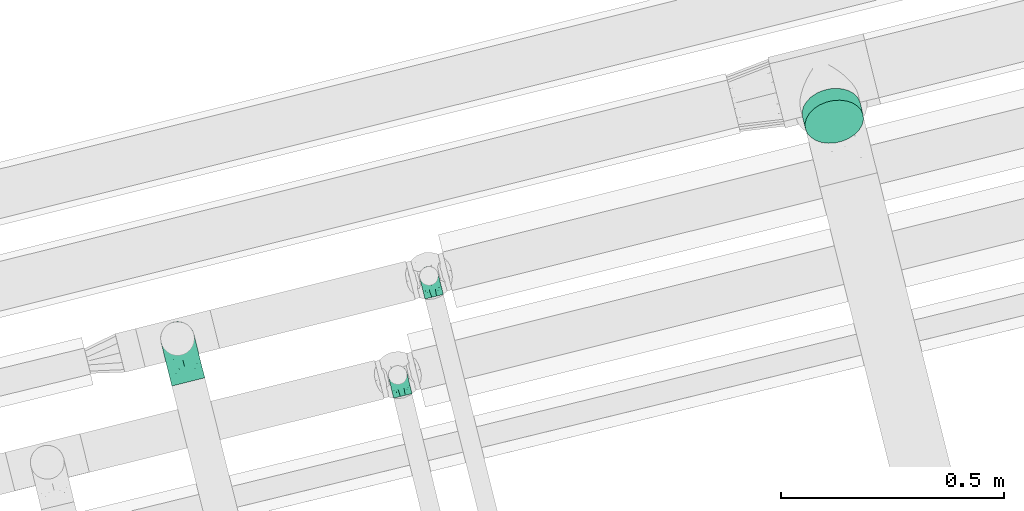
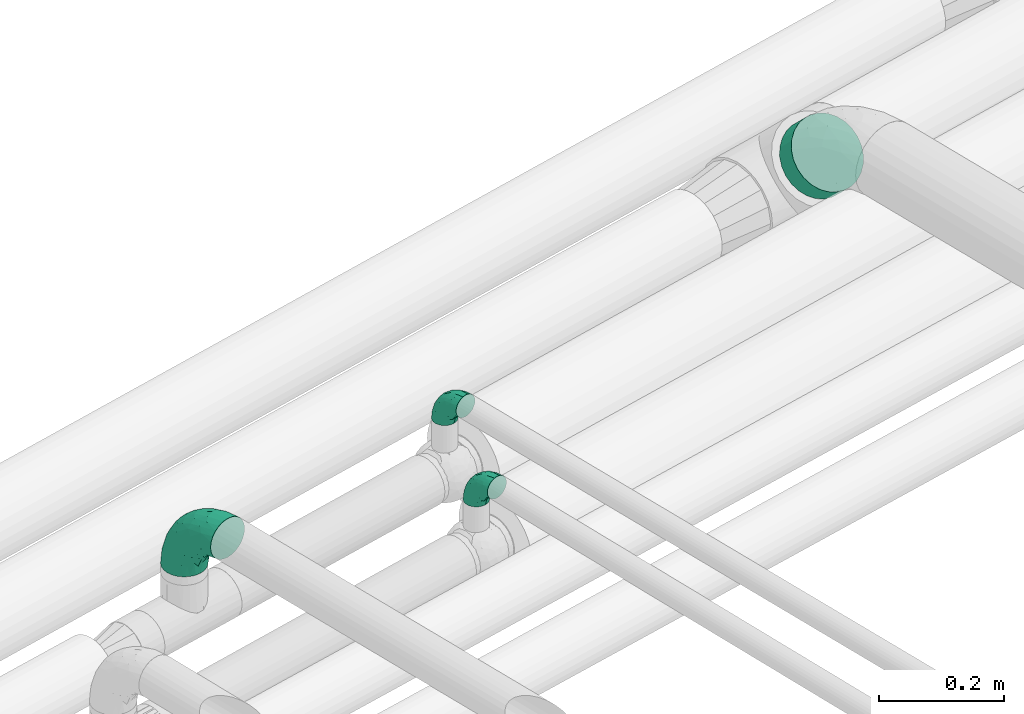
# One storey, part 54 of 93: 3 flow fittings, 1 flow segment.
"""IFC2X3 building model written with IfcOpenShell, lengths in millimetres."""

from ifc_helpers import new_model, entity, si_unit, converted_unit, derived_unit, direction, frame, origin, origin_2d_with_axis, place, context, subcontext, project, spatial, circle, extrude, faceted_brep, source, transform, mapped, material, type_object, type_shapes, element, save


model = new_model("IFC2X3")

# Units and contexts
model_context = context("Model", 3, precision=0.01, world=origin(), true_north=direction((6.12303176911189e-17, 1.0)))
body_context = subcontext(model_context, "Body", "Model", "MODEL_VIEW")
ifc_project = project(units=[si_unit("LENGTHUNIT", "METRE", prefix="MILLI"), si_unit("AREAUNIT", "SQUARE_METRE"), si_unit("VOLUMEUNIT", "CUBIC_METRE"), converted_unit("PLANEANGLEUNIT", "DEGREE", entity("IfcRatioMeasure", 0.0174532925199433), si_unit("PLANEANGLEUNIT", "RADIAN"), dimensions=[0, 0, 0, 0, 0, 0, 0]), si_unit("MASSUNIT", "GRAM", prefix="KILO"), derived_unit("MASSDENSITYUNIT", [(si_unit("MASSUNIT", "GRAM", prefix="KILO"), 1), (si_unit("LENGTHUNIT", "METRE"), -3)]), derived_unit("MOMENTOFINERTIAUNIT", [(si_unit("LENGTHUNIT", "METRE"), 4)]), si_unit("TIMEUNIT", "SECOND"), si_unit("FREQUENCYUNIT", "HERTZ"), si_unit("THERMODYNAMICTEMPERATUREUNIT", "DEGREE_CELSIUS"), derived_unit("THERMALTRANSMITTANCEUNIT", [(si_unit("MASSUNIT", "GRAM", prefix="KILO"), 1), (si_unit("THERMODYNAMICTEMPERATUREUNIT", "KELVIN"), -1), (si_unit("TIMEUNIT", "SECOND"), -3)]), derived_unit("VOLUMETRICFLOWRATEUNIT", [(si_unit("LENGTHUNIT", "METRE"), 3), (si_unit("TIMEUNIT", "SECOND"), -1)]), derived_unit("MASSFLOWRATEUNIT", [(si_unit("MASSUNIT", "GRAM", prefix="KILO"), 1), (si_unit("TIMEUNIT", "SECOND"), -1)]), derived_unit("ROTATIONALFREQUENCYUNIT", [(si_unit("TIMEUNIT", "SECOND"), -1)]), si_unit("ELECTRICCURRENTUNIT", "AMPERE"), si_unit("ELECTRICVOLTAGEUNIT", "VOLT"), si_unit("POWERUNIT", "WATT"), si_unit("FORCEUNIT", "NEWTON", prefix="KILO"), si_unit("ILLUMINANCEUNIT", "LUX"), si_unit("LUMINOUSFLUXUNIT", "LUMEN"), si_unit("LUMINOUSINTENSITYUNIT", "CANDELA"), derived_unit("USERDEFINED", [(si_unit("MASSUNIT", "GRAM", prefix="KILO"), -1), (si_unit("LENGTHUNIT", "METRE"), -2), (si_unit("TIMEUNIT", "SECOND"), 3), (si_unit("LUMINOUSFLUXUNIT", "LUMEN"), 1)]), derived_unit("LINEARVELOCITYUNIT", [(si_unit("LENGTHUNIT", "METRE"), 1), (si_unit("TIMEUNIT", "SECOND"), -1)]), si_unit("PRESSUREUNIT", "PASCAL"), derived_unit("USERDEFINED", [(si_unit("LENGTHUNIT", "METRE"), -2), (si_unit("MASSUNIT", "GRAM", prefix="KILO"), 1), (si_unit("TIMEUNIT", "SECOND"), -2)]), derived_unit("LINEARFORCEUNIT", [(si_unit("MASSUNIT", "GRAM", prefix="KILO"), 1), (si_unit("LENGTHUNIT", "METRE"), 1), (si_unit("TIMEUNIT", "SECOND"), -2), (si_unit("LENGTHUNIT", "METRE"), -1)]), derived_unit("PLANARFORCEUNIT", [(si_unit("MASSUNIT", "GRAM", prefix="KILO"), 1), (si_unit("LENGTHUNIT", "METRE"), 1), (si_unit("TIMEUNIT", "SECOND"), -2), (si_unit("LENGTHUNIT", "METRE"), -2)])], contexts=[model_context])

# Site, building, storey
site_placement = place(None, origin())
site = spatial("IfcSite", under=ifc_project, at=site_placement, CompositionType="ELEMENT")
building_placement = place(site_placement, origin())
building = spatial("IfcBuilding", under=site, at=building_placement, CompositionType="ELEMENT")
storey_placement = place(building_placement, frame((0.0, 0.0, -4200.0)))
storey = spatial("IfcBuildingStorey", under=building, at=storey_placement, CompositionType="ELEMENT", Elevation=-4200.0)

# Flow segment
pipe_segment_type = type_object("IfcPipeSegmentType", PredefinedType="NOTDEFINED")
flow_segment_placement = place(storey_placement, frame((-9939.48, 13051.15, 2518.47)))
element("IfcFlowSegment", 1, at=flow_segment_placement, inside=storey, type_object=pipe_segment_type, context=body_context, shape_type="SweptSolid", body=[
    extrude(circle(Radius=66.5, at=origin_2d_with_axis()), frame((66.89, 76.29, 48.62), z_axis=(0.165599019731802, -0.687453787939549, 0.707095647074307), x_axis=(-0.972191162515673, -0.234188692140385, 0.0)), (0.0, 0.0, 1.0), 38.5556902589995),
])

# Flow fittings
ifc_material = material()
pipe_fitting_type_1 = type_object("IfcPipeFittingType", Name="ADSK_1", PredefinedType="NOTDEFINED", material=ifc_material)
shared_shape_1 = source(origin(), body_context, "Body", "Brep", [
    faceted_brep([(-48.0, 10.6, -18.36), (-48.0, 5.49, -20.48), (-48.0, 0.0, -21.2), (-48.0, -5.49, -20.48), (-48.0, -10.6, -18.36), (-48.0, -14.99, -14.99), (-48.0, -18.36, -10.6), (-48.0, -20.48, -5.49), (-48.0, -21.2, 0.0), (-48.0, -20.48, 5.49), (-48.0, -18.36, 10.6), (-48.0, -14.99, 14.99), (-48.0, -10.6, 18.36), (-48.0, -5.49, 20.48), (-48.0, 0.0, 21.2), (-48.0, 5.49, 20.48), (-48.0, 10.6, 18.36), (-48.0, 14.99, 14.99), (-48.0, 18.36, 10.6), (-48.0, 20.48, 5.49), (-48.0, 21.2, 0.0), (-48.0, 20.48, -5.49), (-48.0, 18.36, -10.6), (-48.0, 14.99, -14.99), (0.0, 48.0, -21.2), (-5.49, 48.0, -20.48), (-10.6, 48.0, -18.36), (-14.99, 48.0, -14.99), (-18.36, 48.0, -10.6), (-20.48, 48.0, -5.49), (-21.2, 48.0, 0.0), (-20.48, 48.0, 5.49), (-18.36, 48.0, 10.6), (-14.99, 48.0, 14.99), (-10.6, 48.0, 18.36), (-5.49, 48.0, 20.48), (0.0, 48.0, 21.2), (5.49, 48.0, 20.48), (10.6, 48.0, 18.36), (14.99, 48.0, 14.99), (18.36, 48.0, 10.6), (20.48, 48.0, 5.49), (21.2, 48.0, 0.0), (20.48, 48.0, -5.49), (18.36, 48.0, -10.6), (14.99, 48.0, -14.99), (10.6, 48.0, -18.36), (5.49, 48.0, -20.48), (-35.25, -16.22, 12.01), (-34.76, -18.57, 0.0), (-20.87, -12.37, 10.9), (-31.49, -11.78, 15.9), (-37.0, -2.58, 20.86), (-33.89, 3.62, 21.15), (-31.81, -18.14, 6.76), (-5.78, 5.78, 17.67), (-19.42, -4.1, 17.86), (-9.6, -3.39, 13.73), (-35.44, -7.73, 19.13), (11.78, 31.49, 15.9), (-5.93, -5.46, 6.95), (-18.45, -13.78, 5.46), (-10.29, -8.43, 0.0), (-24.6, 0.55, 20.62), (-37.28, 17.94, 13.81), (-33.38, 22.85, 9.59), (-41.46, 20.06, 8.75), (-29.51, 20.45, 15.16), (-15.04, 10.79, 21.13), (-7.08, 16.98, 20.93), (-8.39, 23.51, 21.15), (-40.86, 13.03, 17.26), (-8.05, 41.26, 19.83), (-3.21, 35.97, 21.14), (8.53, 19.66, 14.74), (4.1, 19.42, 17.86), (-37.72, 22.66, 4.78), (-37.07, 8.58, 19.98), (-13.0, 5.43, 19.97), (-3.78, 13.93, 19.7), (3.02, 8.69, 13.43), (-2.27, -0.05, 10.65), (6.22, 6.99, 7.09), (-22.25, 34.6, 9.45), (18.14, 31.81, 6.76), (16.22, 35.25, 12.01), (12.37, 20.87, 10.9), (7.73, 35.44, 19.13), (-21.52, -15.93, 0.0), (2.58, 37.0, 20.86), (18.57, 34.76, 0.0), (13.78, 18.45, 5.46), (15.93, 21.52, 0.0), (-20.03, -8.54, 14.9), (-28.6, 28.6, 5.16), (-24.79, 34.6, 0.0), (-34.6, 24.79, 0.0), (-22.81, 37.41, 4.68), (-23.36, 26.33, 14.79), (-13.68, 37.05, 17.49), (-17.72, 38.12, 13.73), (-26.25, 27.3, 11.24), (-9.71, 32.34, 20.14), (-17.26, 25.6, 18.71), (-26.33, 9.99, 20.77), (-24.06, 6.05, 21.2), (-25.02, 15.46, 19.56), (-24.3, 20.72, 17.57), (-31.95, 15.23, 17.8), (-13.53, 24.7, 20.21), (-17.6, 17.6, 20.6), (-0.55, 24.6, 20.62), (-11.41, -7.48, 10.43), (0.93, -0.93, 0.0), (8.43, 10.29, 0.0), (-11.41, -7.48, -10.43), (-20.1, -8.84, -14.66), (-9.6, -3.39, -13.73), (7.73, 35.44, -19.13), (4.1, 19.42, -17.86), (-0.55, 24.6, -20.62), (-38.12, 17.72, -13.73), (-37.05, 13.68, -17.49), (-32.34, 9.71, -20.14), (-41.26, 8.05, -19.83), (-37.41, 22.81, -4.68), (-23.51, 8.39, -21.15), (-35.97, 3.21, -21.14), (-28.6, 28.6, -5.16), (-31.81, -18.14, -6.76), (-18.45, -13.78, -5.46), (-25.6, 17.26, -18.71), (-19.42, -4.1, -17.86), (-17.94, 37.28, -13.81), (-22.85, 33.38, -9.59), (-20.06, 41.46, -8.75), (-31.49, -11.78, -15.9), (-35.25, -16.22, -12.01), (8.53, 19.66, -14.74), (11.78, 31.49, -15.9), (-9.99, 26.33, -20.77), (-6.05, 24.06, -21.2), (-10.79, 15.04, -21.13), (-37.0, -2.58, -20.86), (-16.98, 7.08, -20.93), (-5.43, 13.0, -19.97), (-13.93, 3.78, -19.7), (-20.87, -12.37, -10.9), (-26.33, 23.36, -14.79), (-22.66, 37.72, -4.78), (13.78, 18.45, -5.46), (18.14, 31.81, -6.76), (-15.46, 25.02, -19.56), (-20.72, 24.3, -17.57), (16.22, 35.25, -12.01), (-13.03, 40.86, -17.26), (-8.58, 37.07, -19.98), (2.58, 37.0, -20.86), (-3.62, 33.89, -21.15), (-34.6, 22.25, -9.45), (6.22, 6.99, -7.09), (-20.45, 29.51, -15.16), (-35.44, -7.73, -19.13), (12.37, 20.87, -10.9), (-27.3, 26.25, -11.24), (-15.23, 31.95, -17.8), (-24.7, 13.53, -20.21), (-24.6, 0.55, -20.62), (-5.78, 5.78, -17.67), (-17.6, 17.6, -20.6), (3.02, 8.69, -13.43), (-5.93, -5.46, -6.95), (-2.27, -0.05, -10.65)], [[[0, 1, 2, 3, 4, 5, 6, 7, 8, 9, 10, 11, 12, 13, 14, 15, 16, 17, 18, 19, 20, 21, 22, 23]], [[24, 25, 26, 27, 28, 29, 30, 31, 32, 33, 34, 35, 36, 37, 38, 39, 40, 41, 42, 43, 44, 45, 46, 47]], [[10, 48, 11]], [[9, 8, 49]], [[48, 50, 51]], [[14, 52, 53]], [[10, 54, 48]], [[9, 54, 10]], [[55, 56, 57]], [[51, 12, 11]], [[51, 58, 12]], [[59, 39, 38]], [[60, 61, 62]], [[58, 56, 63]], [[64, 65, 66]], [[67, 65, 64]], [[68, 69, 70]], [[16, 71, 17]], [[13, 52, 14]], [[35, 72, 73]], [[14, 53, 15]], [[17, 64, 18]], [[74, 59, 75]], [[20, 19, 76]], [[66, 19, 18]], [[77, 15, 53]], [[15, 77, 16]], [[69, 78, 79]], [[80, 81, 82]], [[32, 31, 83]], [[84, 85, 86]], [[59, 87, 75]], [[61, 54, 88]], [[36, 89, 37]], [[84, 41, 40]], [[36, 35, 73]], [[90, 41, 84]], [[40, 39, 85]], [[12, 58, 13]], [[85, 84, 40]], [[91, 84, 86]], [[84, 92, 90]], [[87, 38, 37]], [[93, 56, 51]], [[65, 94, 76]], [[94, 95, 96]], [[84, 91, 92]], [[95, 97, 30]], [[98, 99, 100]], [[76, 94, 96]], [[101, 98, 83]], [[100, 99, 33]], [[102, 70, 73]], [[103, 102, 99]], [[94, 97, 95]], [[72, 99, 102]], [[72, 35, 34]], [[34, 33, 99]], [[9, 49, 54]], [[87, 59, 38]], [[104, 105, 68]], [[106, 103, 107]], [[106, 77, 104]], [[71, 64, 17]], [[108, 107, 67]], [[33, 32, 100]], [[109, 103, 110]], [[102, 109, 70]], [[89, 73, 111]], [[50, 48, 54]], [[51, 11, 48]], [[56, 58, 51]], [[88, 54, 49]], [[52, 58, 63]], [[50, 112, 93]], [[56, 55, 78]], [[39, 59, 85]], [[86, 85, 59]], [[89, 87, 37]], [[42, 41, 90]], [[111, 79, 75]], [[111, 75, 87]], [[75, 55, 80]], [[104, 77, 53]], [[71, 77, 108]], [[32, 83, 100]], [[98, 100, 83]], [[99, 98, 103]], [[106, 107, 108]], [[68, 70, 110]], [[111, 73, 70]], [[68, 110, 104]], [[68, 63, 78]], [[57, 93, 112]], [[80, 55, 57]], [[61, 50, 54]], [[80, 82, 86]], [[81, 57, 112]], [[74, 86, 59]], [[60, 113, 82]], [[82, 114, 91]], [[101, 94, 65]], [[97, 94, 83]], [[73, 89, 36]], [[87, 89, 111]], [[58, 52, 13]], [[53, 52, 63]], [[104, 53, 105]], [[106, 104, 110]], [[20, 76, 96]], [[76, 19, 66]], [[103, 106, 110]], [[77, 106, 108]], [[103, 98, 107]], [[67, 107, 98]], [[67, 98, 101]], [[108, 67, 64]], [[53, 63, 105]], [[63, 68, 105]], [[83, 31, 97]], [[30, 97, 31]], [[62, 113, 60]], [[112, 61, 60]], [[61, 88, 62]], [[86, 82, 91]], [[56, 78, 63]], [[114, 82, 113]], [[114, 92, 91]], [[79, 78, 55]], [[75, 79, 55]], [[69, 79, 111]], [[70, 69, 111]], [[78, 69, 68]], [[77, 71, 16]], [[64, 71, 108]], [[64, 66, 18]], [[76, 66, 65]], [[99, 72, 34]], [[73, 72, 102]], [[94, 101, 83]], [[67, 101, 65]], [[75, 80, 74]], [[80, 86, 74]], [[70, 109, 110]], [[102, 103, 109]], [[50, 93, 51]], [[57, 56, 93]], [[61, 112, 50]], [[81, 112, 60]], [[82, 81, 60]], [[80, 57, 81]], [[115, 116, 117]], [[118, 119, 120]], [[121, 122, 23]], [[123, 124, 122]], [[96, 125, 20]], [[123, 126, 127]], [[128, 96, 95]], [[129, 130, 88]], [[123, 122, 131]], [[116, 132, 117]], [[133, 134, 135]], [[0, 124, 1]], [[5, 136, 137]], [[138, 119, 139]], [[129, 88, 49]], [[140, 141, 142]], [[6, 5, 137]], [[46, 118, 47]], [[143, 3, 2]], [[144, 145, 146]], [[6, 129, 7]], [[129, 137, 147]], [[127, 2, 1]], [[148, 122, 121]], [[128, 125, 96]], [[134, 128, 149]], [[95, 149, 128]], [[150, 151, 92]], [[30, 29, 149]], [[152, 131, 153]], [[27, 133, 28]], [[154, 45, 44]], [[136, 5, 4]], [[27, 26, 155]], [[156, 26, 25]], [[24, 157, 158]], [[24, 47, 157]], [[22, 21, 159]], [[160, 150, 114]], [[134, 133, 161]], [[142, 144, 126]], [[46, 139, 118]], [[162, 136, 4]], [[156, 25, 158]], [[1, 124, 127]], [[115, 147, 116]], [[45, 154, 139]], [[139, 46, 45]], [[154, 163, 139]], [[162, 4, 3]], [[42, 90, 43]], [[130, 129, 147]], [[49, 7, 129]], [[43, 151, 44]], [[0, 23, 122]], [[24, 158, 25]], [[136, 162, 132]], [[135, 29, 28]], [[43, 90, 151]], [[164, 148, 159]], [[152, 156, 140]], [[155, 133, 27]], [[165, 153, 161]], [[23, 22, 121]], [[123, 131, 166]], [[123, 166, 126]], [[143, 127, 167]], [[147, 137, 136]], [[8, 7, 49]], [[129, 6, 137]], [[143, 162, 3]], [[167, 146, 132]], [[167, 132, 162]], [[132, 168, 117]], [[44, 151, 154]], [[92, 151, 90]], [[163, 154, 151]], [[119, 118, 139]], [[157, 118, 120]], [[138, 139, 163]], [[119, 168, 145]], [[140, 156, 158]], [[155, 156, 165]], [[22, 159, 121]], [[148, 121, 159]], [[122, 148, 131]], [[152, 153, 165]], [[142, 126, 169]], [[167, 127, 126]], [[142, 169, 140]], [[142, 120, 145]], [[168, 170, 117]], [[160, 171, 172]], [[115, 172, 171]], [[171, 62, 130]], [[119, 170, 168]], [[170, 163, 160]], [[150, 163, 151]], [[113, 171, 160]], [[164, 128, 134]], [[125, 128, 159]], [[127, 143, 2]], [[162, 143, 167]], [[118, 157, 47]], [[158, 157, 120]], [[140, 158, 141]], [[152, 140, 169]], [[30, 149, 95]], [[149, 29, 135]], [[131, 152, 169]], [[156, 152, 165]], [[131, 148, 153]], [[161, 153, 148]], [[161, 148, 164]], [[165, 161, 133]], [[158, 120, 141]], [[120, 142, 141]], [[159, 21, 125]], [[20, 125, 21]], [[115, 130, 147]], [[114, 113, 160]], [[62, 171, 113]], [[62, 88, 130]], [[160, 163, 150]], [[150, 92, 114]], [[119, 145, 120]], [[146, 145, 168]], [[132, 146, 168]], [[144, 146, 167]], [[126, 144, 167]], [[145, 144, 142]], [[156, 155, 26]], [[133, 155, 165]], [[133, 135, 28]], [[149, 135, 134]], [[122, 124, 0]], [[127, 124, 123]], [[128, 164, 159]], [[161, 164, 134]], [[163, 170, 138]], [[170, 119, 138]], [[131, 169, 166]], [[126, 166, 169]], [[147, 136, 116]], [[132, 116, 136]], [[172, 115, 117]], [[130, 115, 171]], [[117, 170, 172]], [[160, 172, 170]]]),
])
type_shapes(pipe_fitting_type_1, [shared_shape_1])
for number, where, z_axis, x_axis, name in (
    (2, (-10773.89, 12755.59, 2650.0), (0.970294391596358, 0.241927248644409, 0.0), (0.0, 0.0, 1.0), "ADSK_1"),
    (3, (-10843.72, 12533.47, 2650.0), (0.972066425938301, 0.234705908667715, 0.0), (0.0, 0.0, 1.0), "ADSK_1"),
):
    element("IfcFlowFitting", number, at=place(storey_placement, frame(where, z_axis=z_axis, x_axis=x_axis)), inside=storey, type_object=pipe_fitting_type_1, material=ifc_material, Name=name, ObjectType="ADSK_1", context=body_context, shape_type="MappedRepresentation", body=[
        mapped(shared_shape_1, transform((0.0, 0.0, 0.0), scale=1.0)),
    ])
pipe_fitting_type_2 = type_object("IfcPipeFittingType", Name="ADSK_2", PredefinedType="NOTDEFINED", material=ifc_material)
shared_shape_2 = source(origin(), body_context, "Body", "Brep", [
    faceted_brep([(-100.0, 19.0, -32.91), (-100.0, 9.84, -36.71), (-100.0, 0.0, -38.0), (-100.0, -9.84, -36.71), (-100.0, -19.0, -32.91), (-100.0, -26.87, -26.87), (-100.0, -32.91, -19.0), (-100.0, -36.71, -9.84), (-100.0, -38.0, 0.0), (-100.0, -36.71, 9.84), (-100.0, -32.91, 19.0), (-100.0, -26.87, 26.87), (-100.0, -19.0, 32.91), (-100.0, -9.84, 36.71), (-100.0, 0.0, 38.0), (-100.0, 9.84, 36.71), (-100.0, 19.0, 32.91), (-100.0, 26.87, 26.87), (-100.0, 32.91, 19.0), (-100.0, 36.71, 9.84), (-100.0, 38.0, 0.0), (-100.0, 36.71, -9.84), (-100.0, 32.91, -19.0), (-100.0, 26.87, -26.87), (-9.84, 100.0, -36.71), (-19.0, 100.0, -32.91), (-26.87, 100.0, -26.87), (-32.91, 100.0, -19.0), (-36.71, 100.0, -9.84), (-38.0, 100.0, 0.0), (-36.71, 100.0, 9.84), (-32.91, 100.0, 19.0), (-26.87, 100.0, 26.87), (-19.0, 100.0, 32.91), (-9.84, 100.0, 36.71), (0.0, 100.0, 38.0), (9.83, 100.0, 36.71), (19.0, 100.0, 32.91), (26.87, 100.0, 26.87), (32.91, 100.0, 19.0), (36.7, 100.0, 9.84), (38.0, 100.0, 0.0), (36.7, 100.0, -9.84), (32.91, 100.0, -19.0), (26.87, 100.0, -26.87), (19.0, 100.0, -32.91), (9.83, 100.0, -36.71), (0.0, 100.0, -38.0), (-40.69, 71.44, 16.62), (-81.22, -35.53, 0.0), (-67.52, -31.95, 12.5), (-8.97, -2.95, 6.59), (-11.71, -2.76, 13.62), (-24.68, -14.61, 8.04), (-64.28, -33.3, 0.0), (-83.72, 23.85, 30.89), (-76.19, 33.07, 24.6), (-74.13, -28.58, 21.76), (13.92, 43.47, 26.56), (5.03, 42.28, 32.41), (2.17, 22.78, 25.61), (20.11, 65.77, 28.71), (-65.77, -20.11, 28.71), (-74.23, -13.22, 34.41), (-44.44, -24.14, 12.16), (-47.64, -26.4, 0.0), (-31.0, -19.51, 0.0), (-54.86, 48.59, 21.12), (-81.56, 37.18, 15.86), (-42.28, -5.03, 32.41), (-52.67, 2.67, 37.1), (-14.76, 85.65, 35.5), (-6.46, 75.04, 37.87), (-58.38, 40.19, 26.6), (-15.88, 37.27, 37.68), (-29.21, 13.39, 36.1), (-10.53, 30.95, 35.7), (-77.78, -4.12, 37.45), (-2.67, 52.67, 37.1), (-76.41, 41.64, 8.45), (-71.15, 7.29, 37.89), (-32.26, 79.13, 24.41), (-44.28, 53.84, 26.08), (-25.18, 76.9, 31.2), (19.6, 43.38, 19.97), (6.25, 18.3, 16.9), (19.92, 34.73, 10.46), (-60.8, 50.97, 7.63), (-76.27, 42.72, 0.0), (-77.34, 15.98, 35.72), (-15.11, 15.11, 32.27), (-22.78, -2.17, 25.61), (28.58, 74.13, 21.76), (31.95, 67.52, 12.5), (-51.02, 30.39, 34.96), (-54.69, 20.06, 37.12), (26.4, 47.64, 0.0), (-51.15, 12.85, 38.0), (-32.84, 22.95, 37.94), (4.12, 77.78, 37.45), (-43.38, -19.6, 19.97), (35.53, 81.22, 0.0), (13.22, 74.23, 34.41), (-39.82, 82.33, 7.34), (-42.72, 76.27, 0.0), (-33.83, 52.47, 33.18), (-48.09, 40.81, 31.48), (-56.16, 56.16, 0.0), (-48.2, 64.18, 8.55), (-18.69, 66.93, 35.98), (-49.98, 57.58, 16.12), (-62.54, 46.99, 14.59), (-43.26, -12.84, 27.42), (-17.52, 48.72, 37.89), (-64.19, 29.4, 31.78), (-27.05, 50.9, 36.03), (-36.14, 36.14, 36.75), (-23.99, -8.71, 19.44), (6.3, 13.34, 7.98), (19.51, 31.0, 0.0), (-7.64, 6.3, 21.15), (-16.71, -8.55, 0.0), (33.3, 64.28, 0.0), (-2.42, 2.42, 0.0), (8.55, 16.71, 0.0), (-85.65, 14.76, -35.5), (-23.85, 83.72, -30.89), (-33.07, 76.19, -24.6), (-75.04, 6.46, -37.87), (-37.27, 15.88, -37.68), (-13.39, 29.21, -36.1), (-30.95, 10.53, -35.7), (-79.13, 32.26, -24.41), (-76.9, 25.18, -31.2), (6.3, 13.34, -7.98), (-11.71, -2.76, -13.62), (6.25, 18.3, -16.9), (-82.33, 39.82, -7.34), (-66.93, 18.69, -35.98), (-48.72, 17.52, -37.89), (-64.18, 48.2, -8.55), (31.95, 67.52, -12.5), (28.58, 74.13, -21.76), (-52.47, 33.83, -33.18), (4.12, 77.78, -37.45), (-7.29, 71.15, -37.89), (-15.98, 77.34, -35.72), (-67.52, -31.95, -12.5), (-30.39, 51.02, -34.96), (-20.06, 54.69, -37.12), (-48.59, 54.86, -21.12), (-37.18, 81.56, -15.86), (-74.13, -28.58, -21.76), (-29.4, 64.19, -31.78), (-40.81, 48.09, -31.48), (-40.19, 58.38, -26.6), (-65.77, -20.11, -28.71), (-74.23, -13.22, -34.41), (-39.81, -22.62, -10.22), (-77.78, -4.12, -37.45), (-43.38, -19.6, -19.97), (-12.85, 51.15, -38.0), (-22.95, 32.84, -37.94), (-71.44, 40.69, -16.62), (19.6, 43.38, -19.97), (20.11, 65.77, -28.71), (-52.67, 2.67, -37.1), (-53.84, 44.28, -26.08), (-41.64, 76.41, -8.45), (-23.99, -8.71, -19.44), (-43.47, -13.92, -26.56), (-22.78, -2.17, -25.61), (-20.59, -12.11, -6.83), (13.22, 74.23, -34.41), (5.03, 42.28, -32.41), (-2.67, 52.67, -37.1), (19.92, 34.73, -10.46), (-42.28, -5.03, -32.41), (12.84, 43.26, -27.42), (-50.97, 60.8, -7.63), (-57.58, 49.98, -16.12), (-46.99, 62.54, -14.59), (-50.9, 27.05, -36.03), (-15.11, 15.11, -32.27), (2.17, 22.78, -25.61), (-36.14, 36.14, -36.75), (-7.64, 6.3, -21.15), (-6.28, -0.33, -7.3)], [[[0, 1, 2, 3, 4, 5, 6, 7, 8, 9, 10, 11, 12, 13, 14, 15, 16, 17, 18, 19, 20, 21, 22, 23]], [[24, 25, 26, 27, 28, 29, 30, 31, 32, 33, 34, 35, 36, 37, 38, 39, 40, 41, 42, 43, 44, 45, 46, 47]], [[31, 30, 48]], [[49, 50, 9]], [[51, 52, 53]], [[9, 50, 10]], [[54, 50, 49]], [[17, 55, 56]], [[11, 10, 57]], [[58, 59, 60]], [[61, 38, 37]], [[62, 12, 11]], [[62, 63, 12]], [[64, 65, 66]], [[56, 67, 68]], [[63, 69, 70]], [[34, 71, 72]], [[67, 56, 73]], [[74, 75, 76]], [[16, 55, 17]], [[13, 77, 14]], [[76, 78, 74]], [[68, 79, 19]], [[18, 17, 56]], [[14, 77, 80]], [[20, 19, 79]], [[81, 82, 83]], [[84, 85, 86]], [[87, 88, 79]], [[18, 68, 19]], [[15, 89, 16]], [[14, 80, 15]], [[85, 84, 60]], [[90, 69, 91]], [[92, 84, 93]], [[94, 89, 95]], [[86, 96, 93]], [[83, 71, 33]], [[95, 97, 98]], [[36, 35, 99]], [[39, 38, 92]], [[39, 93, 40]], [[66, 53, 64]], [[92, 93, 39]], [[57, 100, 62]], [[93, 101, 40]], [[93, 84, 86]], [[61, 102, 59]], [[33, 32, 83]], [[103, 48, 30]], [[50, 57, 10]], [[104, 103, 29]], [[94, 105, 106]], [[104, 107, 108]], [[12, 63, 13]], [[83, 109, 71]], [[83, 105, 109]], [[32, 81, 83]], [[67, 110, 111]], [[108, 103, 104]], [[112, 69, 62]], [[33, 71, 34]], [[35, 34, 72]], [[109, 113, 72]], [[102, 37, 36]], [[102, 61, 37]], [[114, 106, 73]], [[89, 15, 80]], [[32, 31, 81]], [[115, 105, 116]], [[109, 115, 113]], [[99, 72, 78]], [[111, 87, 79]], [[108, 87, 110]], [[69, 63, 62]], [[77, 63, 70]], [[100, 117, 112]], [[69, 90, 75]], [[99, 102, 36]], [[78, 76, 59]], [[78, 59, 102]], [[59, 90, 60]], [[100, 57, 50]], [[62, 11, 57]], [[38, 61, 92]], [[84, 92, 61]], [[95, 89, 80]], [[55, 89, 114]], [[83, 82, 105]], [[94, 106, 114]], [[98, 113, 116]], [[78, 72, 113]], [[98, 116, 95]], [[98, 70, 75]], [[31, 48, 81]], [[82, 81, 48]], [[91, 112, 117]], [[60, 84, 58]], [[113, 115, 116]], [[118, 119, 86]], [[90, 91, 60]], [[91, 117, 120]], [[72, 99, 35]], [[102, 99, 78]], [[63, 77, 13]], [[80, 77, 70]], [[95, 80, 97]], [[94, 95, 116]], [[56, 68, 18]], [[79, 68, 111]], [[110, 87, 111]], [[79, 88, 20]], [[108, 107, 87]], [[88, 87, 107]], [[120, 60, 91]], [[66, 121, 53]], [[118, 86, 85]], [[122, 93, 96]], [[52, 118, 85]], [[118, 123, 124, 119]], [[48, 103, 108]], [[29, 103, 30]], [[89, 55, 16]], [[56, 55, 114]], [[80, 70, 97]], [[70, 98, 97]], [[105, 94, 116]], [[89, 94, 114]], [[105, 82, 106]], [[73, 106, 82]], [[67, 73, 82]], [[114, 73, 56]], [[110, 82, 48]], [[67, 111, 68]], [[82, 110, 67]], [[108, 110, 48]], [[69, 75, 70]], [[76, 75, 90]], [[59, 76, 90]], [[78, 113, 74]], [[113, 98, 74]], [[75, 74, 98]], [[9, 8, 49]], [[101, 93, 122]], [[101, 41, 40]], [[72, 71, 109]], [[50, 54, 65]], [[117, 53, 52]], [[109, 105, 115]], [[100, 112, 62]], [[91, 69, 112]], [[123, 51, 121]], [[120, 52, 85]], [[52, 120, 117]], [[60, 120, 85]], [[51, 118, 52]], [[100, 64, 117]], [[50, 64, 100]], [[121, 51, 53]], [[118, 51, 123]], [[84, 61, 58]], [[59, 58, 61]], [[86, 119, 96]], [[65, 64, 50]], [[117, 64, 53]], [[125, 1, 0]], [[26, 126, 127]], [[2, 1, 128]], [[129, 130, 131]], [[132, 133, 23]], [[134, 135, 136]], [[88, 137, 20]], [[138, 139, 128]], [[88, 107, 140]], [[141, 142, 43]], [[138, 133, 143]], [[47, 144, 145]], [[146, 24, 145]], [[125, 133, 138]], [[6, 147, 7]], [[148, 146, 149]], [[147, 49, 7]], [[127, 150, 151]], [[147, 6, 152]], [[153, 154, 155]], [[156, 4, 157]], [[140, 137, 88]], [[47, 145, 24]], [[42, 41, 101]], [[65, 147, 158]], [[148, 143, 154]], [[159, 3, 2]], [[147, 152, 160]], [[149, 161, 162]], [[156, 5, 4]], [[137, 163, 21]], [[142, 164, 165]], [[131, 166, 129]], [[27, 151, 28]], [[167, 133, 132]], [[168, 29, 28]], [[169, 170, 171]], [[127, 27, 26]], [[150, 127, 155]], [[135, 172, 158]], [[25, 24, 146]], [[1, 125, 128]], [[22, 21, 163]], [[126, 26, 25]], [[151, 168, 28]], [[47, 46, 144]], [[44, 165, 45]], [[0, 23, 133]], [[173, 174, 175]], [[119, 134, 176]], [[142, 44, 43]], [[173, 45, 165]], [[141, 43, 42]], [[45, 173, 46]], [[141, 101, 122]], [[156, 157, 177]], [[157, 4, 3]], [[101, 141, 42]], [[178, 174, 165]], [[169, 160, 170]], [[6, 5, 152]], [[170, 177, 171]], [[158, 147, 160]], [[104, 168, 179]], [[141, 96, 176]], [[150, 180, 181]], [[23, 22, 132]], [[138, 143, 182]], [[138, 182, 139]], [[159, 128, 166]], [[181, 179, 168]], [[140, 179, 180]], [[159, 157, 3]], [[166, 131, 177]], [[166, 177, 157]], [[177, 183, 171]], [[174, 173, 165]], [[144, 173, 175]], [[178, 164, 184]], [[174, 183, 130]], [[5, 156, 152]], [[160, 152, 156]], [[164, 142, 141]], [[165, 44, 142]], [[149, 146, 145]], [[126, 146, 153]], [[133, 167, 143]], [[148, 154, 153]], [[162, 139, 185]], [[166, 128, 139]], [[162, 185, 149]], [[162, 175, 130]], [[22, 163, 132]], [[167, 132, 163]], [[174, 184, 183]], [[136, 176, 134]], [[184, 136, 186]], [[158, 172, 66]], [[136, 184, 164]], [[171, 183, 184]], [[128, 159, 2]], [[157, 159, 166]], [[173, 144, 46]], [[145, 144, 175]], [[149, 145, 161]], [[148, 149, 185]], [[127, 151, 27]], [[168, 151, 181]], [[180, 179, 181]], [[168, 104, 29]], [[140, 107, 179]], [[104, 179, 107]], [[176, 136, 164]], [[135, 169, 186]], [[141, 176, 164]], [[134, 119, 124, 123]], [[158, 66, 65]], [[187, 172, 135]], [[163, 137, 140]], [[20, 137, 21]], [[146, 126, 25]], [[127, 126, 153]], [[145, 175, 161]], [[175, 162, 161]], [[143, 148, 185]], [[146, 148, 153]], [[143, 167, 154]], [[155, 154, 167]], [[150, 155, 167]], [[153, 155, 127]], [[180, 167, 163]], [[150, 181, 151]], [[167, 180, 150]], [[140, 180, 163]], [[174, 130, 175]], [[131, 130, 183]], [[177, 131, 183]], [[166, 139, 129]], [[139, 162, 129]], [[130, 129, 162]], [[49, 147, 54]], [[49, 8, 7]], [[133, 125, 0]], [[128, 125, 138]], [[158, 160, 169]], [[65, 54, 147]], [[187, 135, 134]], [[187, 121, 172]], [[134, 123, 187]], [[143, 185, 182]], [[121, 187, 123]], [[121, 66, 172]], [[139, 182, 185]], [[160, 156, 170]], [[177, 170, 156]], [[186, 169, 171]], [[158, 169, 135]], [[184, 186, 171]], [[135, 186, 136]], [[164, 178, 165]], [[184, 174, 178]], [[96, 141, 122]], [[96, 119, 176]]]),
])
type_shapes(pipe_fitting_type_2, [shared_shape_2])
flow_fitting_placement = place(storey_placement, frame((-11337.02, 12615.18, 2700.0), z_axis=(0.970288704798104, 0.241950055468514, 0.0), x_axis=(0.0, 0.0, 1.0)))
element("IfcFlowFitting", 4, at=flow_fitting_placement, inside=storey, type_object=pipe_fitting_type_2, material=ifc_material, Name="ADSK_2", ObjectType="ADSK_2", context=body_context, shape_type="MappedRepresentation", body=[
    mapped(shared_shape_2, transform((0.0, 0.0, 0.0), scale=1.0)),
])

save(model, "model.ifc")
